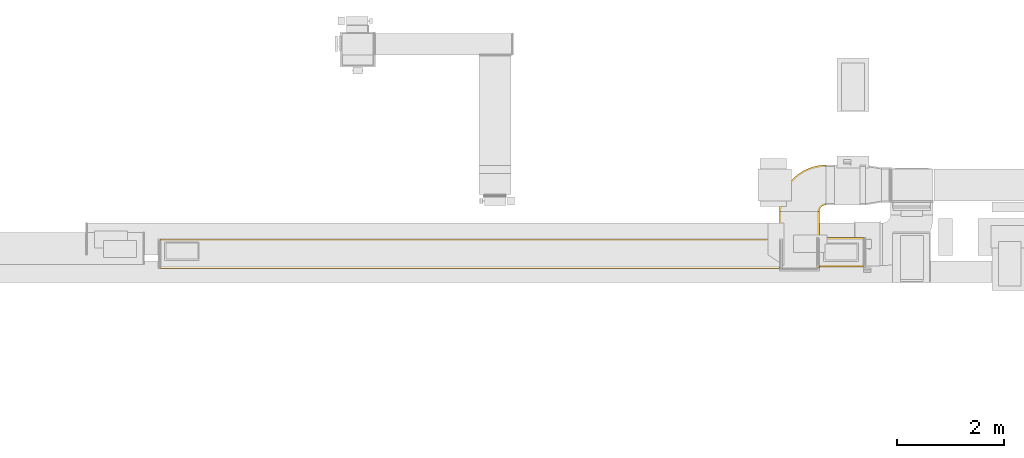
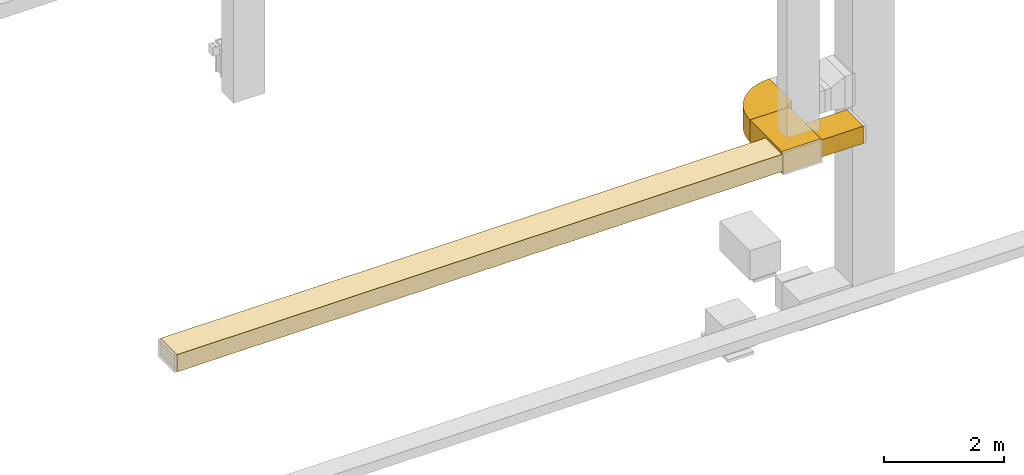
# One storey, part 2 of 25: 4 coverings.
"""IFC2X3 building model written with IfcOpenShell, lengths in millimetres."""

from ifc_helpers import new_model, entity, si_unit, converted_unit, derived_unit, direction, frame, frame_2d, origin, origin_2d_with_axis, place, context, subcontext, project, spatial, polyline, circle_curve, parameter, trimmed, segment, composite_curve, rectangle, outline, extrude, element, save


model = new_model("IFC2X3")

# Units and contexts
model_context = context("Model", 3, precision=0.01, world=origin(), true_north=direction((6.12303176911189e-17, 1.0)))
body_context = subcontext(model_context, "Body", "Model", "MODEL_VIEW")
ifc_project = project(units=[si_unit("LENGTHUNIT", "METRE", prefix="MILLI"), si_unit("AREAUNIT", "SQUARE_METRE"), si_unit("VOLUMEUNIT", "CUBIC_METRE"), converted_unit("PLANEANGLEUNIT", "DEGREE", entity("IfcRatioMeasure", 0.0174532925199433), si_unit("PLANEANGLEUNIT", "RADIAN"), dimensions=[0, 0, 0, 0, 0, 0, 0]), si_unit("MASSUNIT", "GRAM", prefix="KILO"), derived_unit("MASSDENSITYUNIT", [(si_unit("MASSUNIT", "GRAM", prefix="KILO"), 1), (si_unit("LENGTHUNIT", "METRE"), -3)]), derived_unit("MOMENTOFINERTIAUNIT", [(si_unit("LENGTHUNIT", "METRE"), 4)]), si_unit("TIMEUNIT", "SECOND"), si_unit("FREQUENCYUNIT", "HERTZ"), si_unit("THERMODYNAMICTEMPERATUREUNIT", "DEGREE_CELSIUS"), derived_unit("THERMALTRANSMITTANCEUNIT", [(si_unit("MASSUNIT", "GRAM", prefix="KILO"), 1), (si_unit("THERMODYNAMICTEMPERATUREUNIT", "KELVIN"), -1), (si_unit("TIMEUNIT", "SECOND"), -3)]), derived_unit("VOLUMETRICFLOWRATEUNIT", [(si_unit("LENGTHUNIT", "METRE"), 3), (si_unit("TIMEUNIT", "SECOND"), -1)]), derived_unit("MASSFLOWRATEUNIT", [(si_unit("MASSUNIT", "GRAM", prefix="KILO"), 1), (si_unit("TIMEUNIT", "SECOND"), -1)]), derived_unit("ROTATIONALFREQUENCYUNIT", [(si_unit("TIMEUNIT", "SECOND"), -1)]), si_unit("ELECTRICCURRENTUNIT", "AMPERE"), si_unit("ELECTRICVOLTAGEUNIT", "VOLT"), si_unit("POWERUNIT", "WATT"), si_unit("FORCEUNIT", "NEWTON", prefix="KILO"), si_unit("ILLUMINANCEUNIT", "LUX"), si_unit("LUMINOUSFLUXUNIT", "LUMEN"), si_unit("LUMINOUSINTENSITYUNIT", "CANDELA"), derived_unit("USERDEFINED", [(si_unit("MASSUNIT", "GRAM", prefix="KILO"), -1), (si_unit("LENGTHUNIT", "METRE"), -2), (si_unit("TIMEUNIT", "SECOND"), 3), (si_unit("LUMINOUSFLUXUNIT", "LUMEN"), 1)]), derived_unit("LINEARVELOCITYUNIT", [(si_unit("LENGTHUNIT", "METRE"), 1), (si_unit("TIMEUNIT", "SECOND"), -1)]), si_unit("PRESSUREUNIT", "PASCAL"), derived_unit("USERDEFINED", [(si_unit("LENGTHUNIT", "METRE"), -2), (si_unit("MASSUNIT", "GRAM", prefix="KILO"), 1), (si_unit("TIMEUNIT", "SECOND"), -2)]), derived_unit("LINEARFORCEUNIT", [(si_unit("MASSUNIT", "GRAM", prefix="KILO"), 1), (si_unit("LENGTHUNIT", "METRE"), 1), (si_unit("TIMEUNIT", "SECOND"), -2), (si_unit("LENGTHUNIT", "METRE"), -1)]), derived_unit("PLANARFORCEUNIT", [(si_unit("MASSUNIT", "GRAM", prefix="KILO"), 1), (si_unit("LENGTHUNIT", "METRE"), 1), (si_unit("TIMEUNIT", "SECOND"), -2), (si_unit("LENGTHUNIT", "METRE"), -2)])], contexts=[model_context])

# Site, building, storey
site_placement = place(None, origin())
site = spatial("IfcSite", under=ifc_project, at=site_placement, CompositionType="ELEMENT")
building_placement = place(site_placement, origin())
building = spatial("IfcBuilding", under=site, at=building_placement, CompositionType="ELEMENT")
storey_placement = place(building_placement, origin())
storey = spatial("IfcBuildingStorey", under=building, at=storey_placement, CompositionType="ELEMENT", Elevation=0.0)

# Coverings
covering_1_placement = place(storey_placement, frame((61132.5, 9275.08, 2475.0)))
element("IfcCovering", 1, at=covering_1_placement, inside=storey, PredefinedType="INSULATION", context=body_context, shape_type="SweptSolid", body=[
    extrude(rectangle(XDim=831.78346095215, YDim=550.0, at=origin_2d_with_axis()), frame((415.89, 275.0, 0.0), z_axis=(0.0, 0.0, 1.0), x_axis=(-1.0, 0.0, 0.0)), (0.0, 0.0, 1.0), 349.999999999999),
])
covering_2_placement = place(storey_placement, frame((48788.45, 9242.34, 2475.0)))
element("IfcCovering", 2, at=covering_2_placement, inside=storey, PredefinedType="INSULATION", context=body_context, shape_type="SweptSolid", body=[
    extrude(rectangle(XDim=11604.0416533364, YDim=550.000000000001, at=origin_2d_with_axis()), frame((5802.02, 275.0, 0.0)), (0.0, 0.0, 1.0), 350.0),
])
covering_3_placement = place(storey_placement, frame((60387.5, 9250.09, 2425.0)))
element("IfcCovering", 3, at=covering_3_placement, inside=storey, PredefinedType="INSULATION", context=body_context, shape_type="SweptSolid", body=[
    extrude(rectangle(XDim=1058.41426556729, YDim=750.000000000003, at=origin_2d_with_axis()), frame((375.0, 529.21, 0.0), z_axis=(0.0, 0.0, 1.0), x_axis=(0.0, -1.0, 0.0)), (0.0, 0.0, 1.0), 450.0),
])
covering_4_placement = place(storey_placement, frame((60385.91, 10306.9, 2425.0)))
element("IfcCovering", 4, at=covering_4_placement, inside=storey, PredefinedType="INSULATION", context=body_context, shape_type="SweptSolid", body=[
    extrude(outline(composite_curve([segment(polyline([(-250.0, 125.0), (-250.0, -625.0)]), True, "CONTINUOUS"), segment(trimmed(circle_curve(frame_2d((-250.0, 250.0), x_axis=(1.0, 0.0)), 875.0), [parameter(270.0)], [parameter(0.0)], True, "PARAMETER"), True, "CONTINUOUS"), segment(polyline([(625.0, 250.0), (-125.0, 250.0)]), True, "CONTINUOUS"), segment(trimmed(circle_curve(frame_2d((-250.0, 250.0), x_axis=(1.0, 0.0)), 125.0), [parameter(270.0)], [parameter(360.0)], True, "PARAMETER"), False, "CONTINUOUS")], self_intersect=False)), frame((626.6, 251.6, 0.0), z_axis=(0.0, 0.0, -1.0), x_axis=(0.0, 1.0, 0.0)), (0.0, 0.0, -1.0), 450.0),
])

save(model, "model.ifc")
